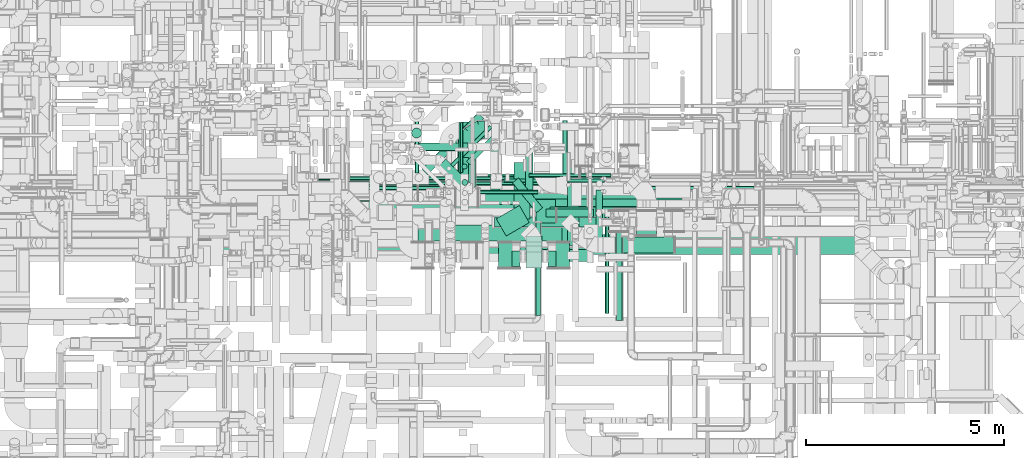
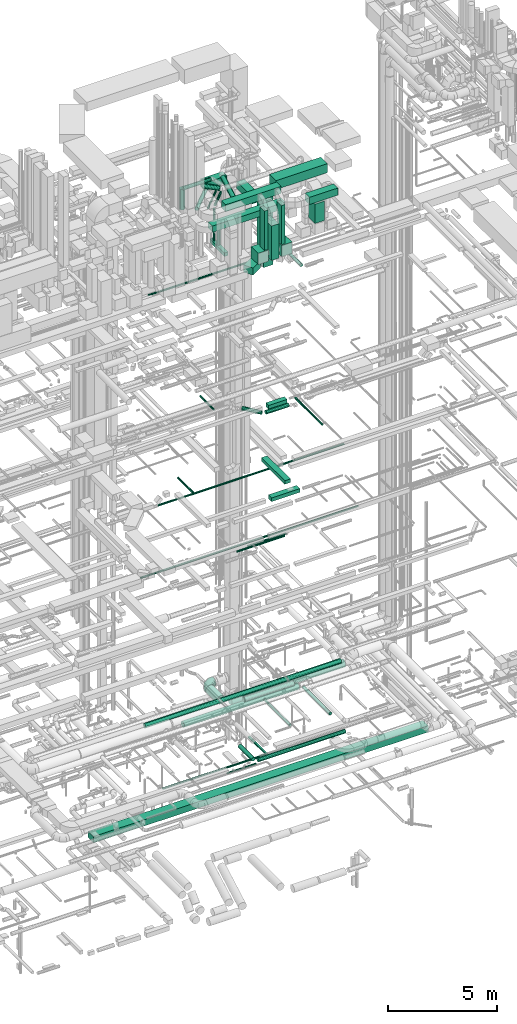
# One storey, part 54 of 337: 51 flow segments, 1 flow fitting.
"""IFC2X3 building model written with IfcOpenShell, lengths in millimetres."""

from ifc_helpers import new_model, entity, si_unit, converted_unit, derived_unit, direction, frame, origin, origin_2d_with_axis, place, context, subcontext, project, spatial, rectangle, circle, extrude, faceted_brep, source, transform, mapped, material, type_object, type_shapes, element, save


model = new_model("IFC2X3")

# Units and contexts
model_context = context("Model", 3, precision=0.01, world=origin(), true_north=direction((6.12303176911189e-17, 1.0)))
body_context = subcontext(model_context, "Body", "Model", "MODEL_VIEW")
ifc_project = project(units=[si_unit("LENGTHUNIT", "METRE", prefix="MILLI"), si_unit("AREAUNIT", "SQUARE_METRE"), si_unit("VOLUMEUNIT", "CUBIC_METRE"), converted_unit("PLANEANGLEUNIT", "DEGREE", entity("IfcRatioMeasure", 0.0174532925199433), si_unit("PLANEANGLEUNIT", "RADIAN"), dimensions=[0, 0, 0, 0, 0, 0, 0]), si_unit("MASSUNIT", "GRAM", prefix="KILO"), derived_unit("MASSDENSITYUNIT", [(si_unit("MASSUNIT", "GRAM", prefix="KILO"), 1), (si_unit("LENGTHUNIT", "METRE"), -3)]), derived_unit("MOMENTOFINERTIAUNIT", [(si_unit("LENGTHUNIT", "METRE"), 4)]), si_unit("TIMEUNIT", "SECOND"), si_unit("FREQUENCYUNIT", "HERTZ"), si_unit("THERMODYNAMICTEMPERATUREUNIT", "DEGREE_CELSIUS"), derived_unit("THERMALTRANSMITTANCEUNIT", [(si_unit("MASSUNIT", "GRAM", prefix="KILO"), 1), (si_unit("THERMODYNAMICTEMPERATUREUNIT", "KELVIN"), -1), (si_unit("TIMEUNIT", "SECOND"), -3)]), derived_unit("VOLUMETRICFLOWRATEUNIT", [(si_unit("LENGTHUNIT", "METRE"), 3), (si_unit("TIMEUNIT", "SECOND"), -1)]), derived_unit("MASSFLOWRATEUNIT", [(si_unit("MASSUNIT", "GRAM", prefix="KILO"), 1), (si_unit("TIMEUNIT", "SECOND"), -1)]), derived_unit("ROTATIONALFREQUENCYUNIT", [(si_unit("TIMEUNIT", "SECOND"), -1)]), si_unit("ELECTRICCURRENTUNIT", "AMPERE"), si_unit("ELECTRICVOLTAGEUNIT", "VOLT"), si_unit("POWERUNIT", "WATT"), si_unit("FORCEUNIT", "NEWTON", prefix="KILO"), si_unit("ILLUMINANCEUNIT", "LUX"), si_unit("LUMINOUSFLUXUNIT", "LUMEN"), si_unit("LUMINOUSINTENSITYUNIT", "CANDELA"), derived_unit("USERDEFINED", [(si_unit("MASSUNIT", "GRAM", prefix="KILO"), -1), (si_unit("LENGTHUNIT", "METRE"), -2), (si_unit("TIMEUNIT", "SECOND"), 3), (si_unit("LUMINOUSFLUXUNIT", "LUMEN"), 1)]), derived_unit("LINEARVELOCITYUNIT", [(si_unit("LENGTHUNIT", "METRE"), 1), (si_unit("TIMEUNIT", "SECOND"), -1)]), si_unit("PRESSUREUNIT", "PASCAL"), derived_unit("USERDEFINED", [(si_unit("LENGTHUNIT", "METRE"), -2), (si_unit("MASSUNIT", "GRAM", prefix="KILO"), 1), (si_unit("TIMEUNIT", "SECOND"), -2)]), derived_unit("LINEARFORCEUNIT", [(si_unit("MASSUNIT", "GRAM", prefix="KILO"), 1), (si_unit("LENGTHUNIT", "METRE"), 1), (si_unit("TIMEUNIT", "SECOND"), -2), (si_unit("LENGTHUNIT", "METRE"), -1)]), derived_unit("PLANARFORCEUNIT", [(si_unit("MASSUNIT", "GRAM", prefix="KILO"), 1), (si_unit("LENGTHUNIT", "METRE"), 1), (si_unit("TIMEUNIT", "SECOND"), -2), (si_unit("LENGTHUNIT", "METRE"), -2)])], contexts=[model_context])

# Site, building, storey
site_placement = place(None, origin())
site = spatial("IfcSite", under=ifc_project, at=site_placement, CompositionType="ELEMENT")
building_placement = place(site_placement, origin())
building = spatial("IfcBuilding", under=site, at=building_placement, CompositionType="ELEMENT")
storey_placement = place(building_placement, origin())
storey = spatial("IfcBuildingStorey", under=building, at=storey_placement, CompositionType="ELEMENT", Elevation=0.0)

# Flow segments
duct_segment_type_1 = type_object("IfcDuctSegmentType", PredefinedType="NOTDEFINED")
flow_segment_1_placement = place(storey_placement, frame((49863.6, 8300.37, -1095.0)))
element("IfcFlowSegment", 1, at=flow_segment_1_placement, inside=storey, type_object=duct_segment_type_1, context=body_context, shape_type="SweptSolid", body=[
    extrude(rectangle(XDim=17725.52076, YDim=500.0, at=origin_2d_with_axis()), frame((8862.76, 250.0, 0.0), z_axis=(0.0, 0.0, 1.0), x_axis=(-1.0, 0.0, 0.0)), (0.0, 0.0, 1.0), 350.0),
])
flow_segment_2_placement = place(storey_placement, frame((59679.84, 9245.12, 19175.0)))
element("IfcFlowSegment", 2, at=flow_segment_2_placement, inside=storey, type_object=duct_segment_type_1, context=body_context, shape_type="SweptSolid", body=[
    extrude(rectangle(XDim=980.000000000003, YDim=249.999999999999, at=origin_2d_with_axis()), frame((490.0, 125.0, 0.0)), (0.0, 0.0, 1.0), 199.999999999998),
])
flow_segment_3_placement = place(storey_placement, frame((60120.56, 8519.63, 15250.0)))
element("IfcFlowSegment", 3, at=flow_segment_3_placement, inside=storey, type_object=duct_segment_type_1, context=body_context, shape_type="SweptSolid", body=[
    extrude(rectangle(XDim=2145.00000000002, YDim=300.000000000001, at=origin_2d_with_axis()), frame((150.0, 1072.5, 0.0), z_axis=(0.0, 0.0, 1.0), x_axis=(0.0, -1.0, 0.0)), (0.0, 0.0, 1.0), 200.000000000002),
])
flow_segment_4_placement = place(storey_placement, frame((59190.56, 8119.63, 14850.0)))
element("IfcFlowSegment", 4, at=flow_segment_4_placement, inside=storey, type_object=duct_segment_type_1, context=body_context, shape_type="SweptSolid", body=[
    extrude(rectangle(XDim=1500.0, YDim=300.0, at=origin_2d_with_axis()), frame((750.0, 150.0, 0.0)), (0.0, 0.0, 1.0), 200.000000000002),
])
flow_segment_5_placement = place(storey_placement, frame((59325.64, 9088.57, 27306.46)))
element("IfcFlowSegment", 5, at=flow_segment_5_placement, inside=storey, type_object=duct_segment_type_1, context=body_context, shape_type="SweptSolid", body=[
    extrude(rectangle(XDim=600.0, YDim=499.999999999999, at=origin_2d_with_axis()), frame((250.0, 300.0, 0.0), z_axis=(0.0, 0.0, 1.0), x_axis=(0.0, -1.0, 0.0)), (0.0, 0.0, 1.0), 3993.54236280399),
])
flow_segment_6_placement = place(storey_placement, frame((61870.03, 8786.6, 29070.0)))
element("IfcFlowSegment", 6, at=flow_segment_6_placement, inside=storey, type_object=duct_segment_type_1, context=body_context, shape_type="SweptSolid", body=[
    extrude(rectangle(XDim=500.000000000008, YDim=600.0, at=origin_2d_with_axis()), frame((250.0, 300.0, 0.0), z_axis=(0.0, 0.0, 1.0), x_axis=(-1.0, 0.0, 0.0)), (0.0, 0.0, 1.0), 1080.00002998999),
])
flow_segment_7_placement = place(storey_placement, frame((61323.5, 8336.6, 30600.0)))
element("IfcFlowSegment", 7, at=flow_segment_7_placement, inside=storey, type_object=duct_segment_type_1, context=body_context, shape_type="SweptSolid", body=[
    extrude(rectangle(XDim=1496.99999999988, YDim=400.0, at=origin_2d_with_axis()), frame((748.5, 200.0, 0.0), z_axis=(0.0, 0.0, 1.0), x_axis=(-1.0, 0.0, 0.0)), (0.0, 0.0, 1.0), 399.999999999996),
])
flow_segment_8_placement = place(storey_placement, frame((56361.0, 8636.6, 30600.0)))
element("IfcFlowSegment", 8, at=flow_segment_8_placement, inside=storey, type_object=duct_segment_type_1, context=body_context, shape_type="SweptSolid", body=[
    extrude(rectangle(XDim=3847.2072124502, YDim=400.0, at=origin_2d_with_axis()), frame((1923.6, 200.0, 0.0), z_axis=(0.0, 0.0, 1.0), x_axis=(-1.0, 0.0, 0.0)), (0.0, 0.0, 1.0), 349.999999999998),
])
flow_segment_9_placement = place(storey_placement, frame((57447.0, 11239.32, 31000.0)))
element("IfcFlowSegment", 9, at=flow_segment_9_placement, inside=storey, type_object=duct_segment_type_1, context=body_context, shape_type="SweptSolid", body=[
    extrude(rectangle(XDim=1182.90417000001, YDim=400.0, at=origin_2d_with_axis()), frame((591.45, 200.0, 0.0), z_axis=(0.0, 0.0, 1.0), x_axis=(-1.0, 0.0, 0.0)), (0.0, 0.0, 1.0), 400.000000000004),
])
for number, where in (
    (10, (58380.38, 7958.29, 28502.0)),
    (11, (59630.38, 7958.29, 28502.0)),
):
    element("IfcFlowSegment", number, at=place(storey_placement, frame(where)), inside=storey, type_object=duct_segment_type_1, context=body_context, shape_type="SweptSolid", body=[
        extrude(rectangle(XDim=630.0, YDim=549.999999999996, at=origin_2d_with_axis()), frame((275.0, 315.0, 0.0), z_axis=(0.0, 0.0, 1.0), x_axis=(0.0, 1.0, 0.0)), (0.0, 0.0, 1.0), 630.000000000004),
    ])
flow_segment_10_placement = place(storey_placement, frame((59630.38, 7988.0, 29152.0)))
element("IfcFlowSegment", 12, at=flow_segment_10_placement, inside=storey, type_object=duct_segment_type_1, context=body_context, shape_type="SweptSolid", body=[
    extrude(rectangle(XDim=200.000000000007, YDim=400.0, at=origin_2d_with_axis()), frame((100.0, 200.0, 0.0)), (0.0, 0.0, 1.0), 2197.99997500005),
])
flow_segment_11_placement = place(storey_placement, frame((57060.5, 8638.29, 31500.0)))
element("IfcFlowSegment", 13, at=flow_segment_11_placement, inside=storey, type_object=duct_segment_type_1, context=body_context, shape_type="SweptSolid", body=[
    extrude(rectangle(XDim=2925.88456999998, YDim=400.0, at=origin_2d_with_axis()), frame((1462.94, 200.0, 0.0)), (0.0, 0.0, 1.0), 399.999999999996),
])
flow_segment_12_placement = place(storey_placement, frame((58730.38, 7988.0, 29152.0)))
element("IfcFlowSegment", 14, at=flow_segment_12_placement, inside=storey, type_object=duct_segment_type_1, context=body_context, shape_type="SweptSolid", body=[
    extrude(rectangle(XDim=200.000000000007, YDim=400.0, at=origin_2d_with_axis()), frame((100.0, 200.0, 0.0)), (0.0, 0.0, 1.0), 2197.99997500005),
])
flow_segment_13_placement = place(storey_placement, frame((58329.55, 8762.06, 27350.0)))
element("IfcFlowSegment", 15, at=flow_segment_13_placement, inside=storey, type_object=duct_segment_type_1, context=body_context, shape_type="SweptSolid", body=[
    extrude(rectangle(XDim=672.825030727756, YDim=499.999999999994, at=origin_2d_with_axis()), frame((416.34, 384.71, 0.0), z_axis=(0.0, 0.0, 1.0), x_axis=(0.86602540378444, 0.499999999999997, 0.0)), (0.0, 0.0, 1.0), 400.000000000004),
])
flow_segment_14_placement = place(storey_placement, frame((58780.38, 9194.29, 31000.0)))
element("IfcFlowSegment", 16, at=flow_segment_14_placement, inside=storey, type_object=duct_segment_type_1, context=body_context, shape_type="SweptSolid", body=[
    extrude(rectangle(XDim=1421.34163000006, YDim=400.000000000004, at=origin_2d_with_axis()), frame((200.0, 710.67, 0.0), z_axis=(0.0, 0.0, 1.0), x_axis=(0.0, 1.0, 0.0)), (0.0, 0.0, 1.0), 400.000000000004),
])
flow_segment_15_placement = place(storey_placement, frame((59080.38, 7960.0, 28475.0)))
element("IfcFlowSegment", 17, at=flow_segment_15_placement, inside=storey, type_object=duct_segment_type_1, context=body_context, shape_type="SweptSolid", body=[
    extrude(rectangle(XDim=800.000000000001, YDim=399.999999999996, at=origin_2d_with_axis()), frame((200.0, 400.0, 0.0), z_axis=(0.0, 0.0, 1.0), x_axis=(0.0, -1.0, 0.0)), (0.0, 0.0, 1.0), 1926.76945188012),
])
flow_segment_16_placement = place(storey_placement, frame((57431.19, 9402.81, 28400.0)))
element("IfcFlowSegment", 18, at=flow_segment_16_placement, inside=storey, type_object=duct_segment_type_1, context=body_context, shape_type="SweptSolid", body=[
    extrude(rectangle(XDim=1340.0, YDim=199.999999999998, at=origin_2d_with_axis()), frame((100.0, 670.0, 0.0), z_axis=(0.0, 0.0, 1.0), x_axis=(0.0, -1.0, 0.0)), (0.0, 0.0, 1.0), 199.999999999998),
])
duct_segment_type_2 = type_object("IfcDuctSegmentType", PredefinedType="NOTDEFINED")
flow_segment_17_placement = place(storey_placement, frame((59998.56, 10005.87, -849.1)))
element("IfcFlowSegment", 19, at=flow_segment_17_placement, inside=storey, type_object=duct_segment_type_2, context=body_context, shape_type="SweptSolid", body=[
    extrude(circle(Radius=62.5, at=origin_2d_with_axis()), frame((64.1, 0.0, 64.1), z_axis=(0.0, 1.0, 0.0), x_axis=(-1.0, 0.0, 0.0)), (0.0, 0.0, 1.0), 1675.0),
])
flow_segment_18_placement = place(storey_placement, frame((54546.9, 10031.99, -836.6)))
element("IfcFlowSegment", 20, at=flow_segment_18_placement, inside=storey, type_object=duct_segment_type_2, context=body_context, shape_type="SweptSolid", body=[
    extrude(circle(Radius=50.0, at=origin_2d_with_axis()), frame((0.0, 51.6, 51.6), z_axis=(1.0, 0.0, 0.0), x_axis=(0.0, -1.0, 0.0)), (0.0, 0.0, 1.0), 5433.24657999997),
])
flow_segment_19_placement = place(storey_placement, frame((59060.41, 9748.98, -651.6)))
element("IfcFlowSegment", 21, at=flow_segment_19_placement, inside=storey, type_object=duct_segment_type_2, context=body_context, shape_type="SweptSolid", body=[
    extrude(circle(Radius=100.0, at=origin_2d_with_axis()), frame((101.6, 0.0, 101.6), z_axis=(0.0, 1.0, 0.0), x_axis=(1.0, 0.0, 0.0)), (0.0, 0.0, 1.0), 1225.42779752531),
])
flow_segment_20_placement = place(storey_placement, frame((57831.35, 9821.97, -1001.6)))
element("IfcFlowSegment", 22, at=flow_segment_20_placement, inside=storey, type_object=duct_segment_type_2, context=body_context, shape_type="SweptSolid", body=[
    extrude(circle(Radius=50.0, at=origin_2d_with_axis()), frame((0.0, 51.6, 51.6), z_axis=(1.0, 0.0, 0.0), x_axis=(0.0, -1.0, 0.0)), (0.0, 0.0, 1.0), 1556.34530999995),
])
flow_segment_21_placement = place(storey_placement, frame((57358.53, 10000.0, 2939.23)))
element("IfcFlowSegment", 23, at=flow_segment_21_placement, inside=storey, type_object=duct_segment_type_2, context=body_context, shape_type="SweptSolid", body=[
    extrude(circle(Radius=225.0, at=origin_2d_with_axis()), frame((226.6, 0.0, 226.6), z_axis=(0.0, 1.0, 0.0), x_axis=(1.0, 0.0, 0.0)), (0.0, 0.0, 1.0), 989.573923827316),
])
flow_segment_22_placement = place(storey_placement, frame((59155.78, 10234.73, 10998.4)))
element("IfcFlowSegment", 24, at=flow_segment_22_placement, inside=storey, type_object=duct_segment_type_2, context=body_context, shape_type="SweptSolid", body=[
    extrude(circle(Radius=50.0, at=origin_2d_with_axis()), frame((0.0, 51.6, 51.6), z_axis=(1.0, 0.0, 0.0), x_axis=(0.0, -1.0, 0.0)), (0.0, 0.0, 1.0), 2061.43743244448),
])
flow_segment_23_placement = place(storey_placement, frame((58527.28, 10104.0, 10998.4)))
element("IfcFlowSegment", 25, at=flow_segment_23_placement, inside=storey, type_object=duct_segment_type_2, context=body_context, shape_type="SweptSolid", body=[
    extrude(circle(Radius=50.0, at=origin_2d_with_axis()), frame((0.0, 51.6, 51.6), z_axis=(1.0, 0.0, 0.0), x_axis=(0.0, -1.0, 0.0)), (0.0, 0.0, 1.0), 2528.57879028175),
])
flow_segment_24_placement = place(storey_placement, frame((57387.84, 10357.4, 19198.4)))
element("IfcFlowSegment", 26, at=flow_segment_24_placement, inside=storey, type_object=duct_segment_type_2, context=body_context, shape_type="SweptSolid", body=[
    extrude(circle(Radius=50.0, at=origin_2d_with_axis()), frame((51.6, 0.0, 51.6), z_axis=(0.0, 1.0, 0.0), x_axis=(1.0, 0.0, 0.0)), (0.0, 0.0, 1.0), 1273.00545368704),
])
flow_segment_25_placement = place(storey_placement, frame((61068.43, 6808.61, 19223.4)))
element("IfcFlowSegment", 27, at=flow_segment_25_placement, inside=storey, type_object=duct_segment_type_2, context=body_context, shape_type="SweptSolid", body=[
    extrude(circle(Radius=50.0, at=origin_2d_with_axis()), frame((51.6, 0.0, 51.6), z_axis=(0.0, 1.0, 0.0), x_axis=(-1.0, 0.0, 0.0)), (0.0, 0.0, 1.0), 2494.01008030507),
])
flow_segment_26_placement = place(storey_placement, frame((54425.03, 10223.45, 14948.4)))
element("IfcFlowSegment", 28, at=flow_segment_26_placement, inside=storey, type_object=duct_segment_type_2, context=body_context, shape_type="SweptSolid", body=[
    extrude(circle(Radius=50.0, at=origin_2d_with_axis()), frame((0.0, 51.6, 51.6), z_axis=(1.0, 0.0, 0.0), x_axis=(0.0, 1.0, 0.0)), (0.0, 0.0, 1.0), 9840.00000000001),
])
flow_segment_27_placement = place(storey_placement, frame((56274.47, 10345.04, 14948.4)))
element("IfcFlowSegment", 29, at=flow_segment_27_placement, inside=storey, type_object=duct_segment_type_2, context=body_context, shape_type="SweptSolid", body=[
    extrude(circle(Radius=50.0, at=origin_2d_with_axis()), frame((51.6, 0.0, 51.6), z_axis=(0.0, 1.0, 0.0), x_axis=(1.0, 0.0, 0.0)), (0.0, 0.0, 1.0), 1395.29999999991),
])
flow_segment_28_placement = place(storey_placement, frame((58735.14, 9348.18, 18873.22)))
element("IfcFlowSegment", 30, at=flow_segment_28_placement, inside=storey, type_object=duct_segment_type_2, context=body_context, shape_type="SweptSolid", body=[
    extrude(circle(Radius=100.0, at=origin_2d_with_axis()), frame((79.31, 815.08, 101.6), z_axis=(0.629320391049814, -0.77714596145699, 0.0), x_axis=(0.77714596145699, 0.629320391049814, 0.0)), (0.0, 0.0, 1.0), 965.778249625125),
])
flow_segment_29_placement = place(storey_placement, frame((59577.67, 9236.98, 18873.22)))
element("IfcFlowSegment", 31, at=flow_segment_29_placement, inside=storey, type_object=duct_segment_type_2, context=body_context, shape_type="SweptSolid", body=[
    extrude(circle(Radius=100.0, at=origin_2d_with_axis()), frame((0.0, 101.6, 101.6), z_axis=(1.0, 0.0, 0.0), x_axis=(0.0, -1.0, 0.0)), (0.0, 0.0, 1.0), 1198.34194170647),
])
flow_segment_30_placement = place(storey_placement, frame((60846.85, 8402.41, 27218.4)))
element("IfcFlowSegment", 32, at=flow_segment_30_placement, inside=storey, type_object=duct_segment_type_2, context=body_context, shape_type="SweptSolid", body=[
    extrude(circle(Radius=80.0, at=origin_2d_with_axis()), frame((81.6, 0.0, 81.6), z_axis=(0.0, 1.0, 0.0), x_axis=(-1.0, 0.0, 0.0)), (0.0, 0.0, 1.0), 1520.0),
])
flow_segment_31_placement = place(storey_placement, frame((53844.42, 10158.38, 26948.4)))
element("IfcFlowSegment", 33, at=flow_segment_31_placement, inside=storey, type_object=duct_segment_type_2, context=body_context, shape_type="SweptSolid", body=[
    extrude(circle(Radius=50.0, at=origin_2d_with_axis()), frame((0.0, 51.6, 51.6), z_axis=(1.0, 0.0, 0.0), x_axis=(0.0, -1.0, 0.0)), (0.0, 0.0, 1.0), 7094.65233084021),
])
flow_segment_32_placement = place(storey_placement, frame((56880.54, 9935.08, 31673.4)))
element("IfcFlowSegment", 34, at=flow_segment_32_placement, inside=storey, type_object=duct_segment_type_2, context=body_context, shape_type="SweptSolid", body=[
    extrude(circle(Radius=125.0, at=origin_2d_with_axis()), frame((88.98, 678.1, 126.6), z_axis=(0.715056088085973, -0.699067086116336, 0.0), x_axis=(-0.699067086116336, -0.715056088085973, 0.0)), (0.0, 0.0, 1.0), 839.864573474785),
])
flow_segment_33_placement = place(storey_placement, frame((57459.9, 10036.46, 28620.0)))
element("IfcFlowSegment", 35, at=flow_segment_33_placement, inside=storey, type_object=duct_segment_type_2, context=body_context, shape_type="SweptSolid", body=[
    extrude(circle(Radius=75.0, at=origin_2d_with_axis()), frame((76.6, 76.6, 0.0), z_axis=(0.0, 0.0, 1.0), x_axis=(-1.0, 0.0, 0.0)), (0.0, 0.0, 1.0), 1059.99999999996),
])
flow_segment_34_placement = place(storey_placement, frame((57170.26, 10496.57, 30448.4)))
element("IfcFlowSegment", 36, at=flow_segment_34_placement, inside=storey, type_object=duct_segment_type_2, context=body_context, shape_type="SweptSolid", body=[
    extrude(circle(Radius=50.0, at=origin_2d_with_axis()), frame((36.95, 36.95, 51.6), z_axis=(0.707106781186554, 0.707106781186541, 0.0), x_axis=(0.707106781186541, -0.707106781186554, 0.0)), (0.0, 0.0, 1.0), 1398.57864376272),
])
flow_segment_35_placement = place(storey_placement, frame((57467.1, 10448.72, 28620.0)))
element("IfcFlowSegment", 37, at=flow_segment_35_placement, inside=storey, type_object=duct_segment_type_2, context=body_context, shape_type="SweptSolid", body=[
    extrude(circle(Radius=62.5, at=origin_2d_with_axis()), frame((64.1, 64.1, 0.0)), (0.0, 0.0, 1.0), 1752.49999999999),
])
flow_segment_36_placement = place(storey_placement, frame((57573.79, 10555.41, 30433.4)))
element("IfcFlowSegment", 38, at=flow_segment_36_placement, inside=storey, type_object=duct_segment_type_2, context=body_context, shape_type="SweptSolid", body=[
    extrude(circle(Radius=62.5, at=origin_2d_with_axis()), frame((45.79, 45.79, 64.1), z_axis=(0.707106781186554, 0.707106781186541, 0.0), x_axis=(-0.707106781186541, 0.707106781186554, 0.0)), (0.0, 0.0, 1.0), 1059.02396590333),
])
flow_segment_37_placement = place(storey_placement, frame((56449.12, 10303.18, 30698.4)))
element("IfcFlowSegment", 39, at=flow_segment_37_placement, inside=storey, type_object=duct_segment_type_2, context=body_context, shape_type="SweptSolid", body=[
    extrude(circle(Radius=100.0, at=origin_2d_with_axis()), frame((72.31, 72.31, 101.6), z_axis=(0.707106781186542, 0.707106781186553, 0.0), x_axis=(0.707106781186553, -0.707106781186542, 0.0)), (0.0, 0.0, 1.0), 2008.42067794927),
])
flow_segment_38_placement = place(storey_placement, frame((56159.0, 10902.63, 31599.45)))
element("IfcFlowSegment", 40, at=flow_segment_38_placement, inside=storey, type_object=duct_segment_type_2, context=body_context, shape_type="SweptSolid", body=[
    extrude(circle(Radius=100.0, at=origin_2d_with_axis()), frame((0.0, 101.6, 101.6), z_axis=(1.0, 0.0, 0.0), x_axis=(0.0, 1.0, 0.0)), (0.0, 0.0, 1.0), 1462.14983405105),
])
flow_segment_39_placement = place(storey_placement, frame((56193.9, 11230.94, 30295.82)))
element("IfcFlowSegment", 41, at=flow_segment_39_placement, inside=storey, type_object=duct_segment_type_2, context=body_context, shape_type="SweptSolid", body=[
    extrude(circle(Radius=125.0, at=origin_2d_with_axis()), frame((126.6, 126.6, 0.0), z_axis=(0.0, 0.0, 1.0), x_axis=(-1.0, 0.0, 0.0)), (0.0, 0.0, 1.0), 1154.17547991571),
])
flow_segment_40_placement = place(storey_placement, frame((58178.44, 9890.53, 30812.35)))
element("IfcFlowSegment", 42, at=flow_segment_40_placement, inside=storey, type_object=duct_segment_type_2, context=body_context, shape_type="SweptSolid", body=[
    extrude(circle(Radius=125.0, at=origin_2d_with_axis()), frame((126.6, 64.1, 109.85), z_axis=(0.0, 0.866025403784435, 0.500000000000006), x_axis=(0.0, 0.500000000000006, -0.866025403784435)), (0.0, 0.0, 1.0), 1307.45626711628),
])
flow_segment_41_placement = place(storey_placement, frame((58286.4, 8982.05, 3373.43)))
element("IfcFlowSegment", 43, at=flow_segment_41_placement, inside=storey, type_object=duct_segment_type_2, context=body_context, shape_type="SweptSolid", body=[
    extrude(circle(Radius=125.0, at=origin_2d_with_axis()), frame((0.0, 126.6, 126.6), z_axis=(1.0, 0.0, -2.03279015452354e-06), x_axis=(0.0, 1.0, 0.0)), (0.0, 0.0, 1.0), 2620.99996522023),
])
flow_segment_42_placement = place(storey_placement, frame((59322.96, 6750.67, 3035.88)))
element("IfcFlowSegment", 44, at=flow_segment_42_placement, inside=storey, type_object=duct_segment_type_2, context=body_context, shape_type="SweptSolid", body=[
    extrude(circle(Radius=62.5, at=origin_2d_with_axis()), frame((64.1, 2347.71, 64.1), z_axis=(0.0, -1.0, 1.21915181881916e-05), x_axis=(1.0, 0.0, 0.0)), (0.0, 0.0, 1.0), 2347.71334194841),
])
flow_segment_43_placement = place(storey_placement, frame((61356.42, 6625.67, 3018.4)))
element("IfcFlowSegment", 45, at=flow_segment_43_placement, inside=storey, type_object=duct_segment_type_2, context=body_context, shape_type="SweptSolid", body=[
    extrude(circle(Radius=80.0, at=origin_2d_with_axis()), frame((81.6, 0.0, 81.6), z_axis=(0.0, 1.0, 0.0), x_axis=(-1.0, 0.0, 0.0)), (0.0, 0.0, 1.0), 2452.71541143044),
])
flow_segment_44_placement = place(storey_placement, frame((55144.83, 9116.79, 2940.9)))
element("IfcFlowSegment", 46, at=flow_segment_44_placement, inside=storey, type_object=duct_segment_type_2, context=body_context, shape_type="SweptSolid", body=[
    extrude(circle(Radius=157.5, at=origin_2d_with_axis()), frame((0.0, 159.1, 159.1), z_axis=(1.0, 0.0, 0.0), x_axis=(0.0, 1.0, 0.0)), (0.0, 0.0, 1.0), 6108.43145732592),
])
flow_segment_45_placement = place(storey_placement, frame((57925.32, 9548.4, 2966.44)))
element("IfcFlowSegment", 47, at=flow_segment_45_placement, inside=storey, type_object=duct_segment_type_2, context=body_context, shape_type="SweptSolid", body=[
    extrude(circle(Radius=200.0, at=origin_2d_with_axis()), frame((0.0, 201.6, 201.6), z_axis=(1.0, 0.0, 0.0), x_axis=(0.0, -1.0, 0.0)), (0.0, 0.0, 1.0), 6016.49865140724),
])
flow_segment_46_placement = place(storey_placement, frame((53269.56, 9405.9, 3393.4)))
element("IfcFlowSegment", 48, at=flow_segment_46_placement, inside=storey, type_object=duct_segment_type_2, context=body_context, shape_type="SweptSolid", body=[
    extrude(circle(Radius=125.0, at=origin_2d_with_axis()), frame((0.0, 126.6, 126.6), z_axis=(1.0, 0.0, 0.0), x_axis=(0.0, 1.0, 0.0)), (0.0, 0.0, 1.0), 10378.4062043357),
])
flow_segment_47_placement = place(storey_placement, frame((53309.89, 9915.2, 11468.4)))
element("IfcFlowSegment", 49, at=flow_segment_47_placement, inside=storey, type_object=duct_segment_type_2, context=body_context, shape_type="SweptSolid", body=[
    extrude(circle(Radius=50.0, at=origin_2d_with_axis()), frame((0.0, 51.6, 51.6), z_axis=(1.0, 0.0, 0.0), x_axis=(0.0, -1.0, 0.0)), (0.0, 0.0, 1.0), 11522.5957397877),
])
flow_segment_48_placement = place(storey_placement, frame((59312.01, 9497.39, -651.6)))
element("IfcFlowSegment", 50, at=flow_segment_48_placement, inside=storey, type_object=duct_segment_type_2, context=body_context, shape_type="SweptSolid", body=[
    extrude(circle(Radius=100.0, at=origin_2d_with_axis()), frame((0.0, 101.6, 101.6), z_axis=(1.0, 0.0, 0.0), x_axis=(0.0, -1.0, 0.0)), (0.0, 0.0, 1.0), 4621.77068899),
])
duct_segment_type_3 = type_object("IfcDuctSegmentType", PredefinedType="NOTDEFINED")
flow_segment_49_placement = place(storey_placement, frame((59975.64, 9088.57, 31450.0)))
element("IfcFlowSegment", 51, at=flow_segment_49_placement, inside=storey, type_object=duct_segment_type_3, context=body_context, shape_type="SweptSolid", body=[
    extrude(rectangle(XDim=2734.46987209406, YDim=600.0, at=origin_2d_with_axis()), frame((1367.23, 300.0, 0.0), z_axis=(0.0, 0.0, 1.0), x_axis=(-1.0, 0.0, 0.0)), (0.0, 0.0, 1.0), 499.999999999999),
])

# Flow fitting
ifc_material = material()
duct_fitting_type = type_object("IfcDuctFittingType", PredefinedType="NOTDEFINED", material=ifc_material)
shared_shape = source(origin(), body_context, "Body", "Brep", [
    faceted_brep([(-450.0, 0.0, -225.0), (-450.0, -50.07, -219.36), (-450.0, -97.62, -202.72), (-450.0, -140.29, -175.91), (-450.0, -175.91, -140.29), (-450.0, -202.72, -97.62), (-450.0, -219.36, -50.07), (-450.0, -225.0, 0.0), (-450.0, -219.36, 50.07), (-450.0, -202.72, 97.62), (-450.0, -175.91, 140.29), (-450.0, -140.29, 175.91), (-450.0, -97.62, 202.72), (-450.0, -50.07, 219.36), (-450.0, 0.0, 225.0), (-450.0, 50.07, 219.36), (-450.0, 97.62, 202.72), (-450.0, 140.29, 175.91), (-450.0, 175.91, 140.29), (-450.0, 202.72, 97.62), (-450.0, 219.36, 50.07), (-450.0, 225.0, 0.0), (-450.0, 219.36, -50.07), (-450.0, 202.72, -97.62), (-450.0, 175.91, -140.29), (-450.0, 140.29, -175.91), (-450.0, 97.62, -202.72), (-450.0, 50.07, -219.36), (-329.42, 0.0, 225.0), (-342.84, 50.07, 219.36), (-355.58, 97.62, 202.72), (-367.01, 140.29, 175.91), (-376.56, 175.91, 140.29), (-383.74, 202.72, 97.62), (-388.2, 219.36, 50.07), (-389.71, 225.0, 0.0), (-388.2, 219.36, -50.07), (-383.74, 202.72, -97.62), (-376.56, 175.91, -140.29), (-367.01, 140.29, -175.91), (-355.58, 97.62, -202.72), (-342.84, 50.07, -219.36), (-329.42, 0.0, -225.0), (-316.01, -50.07, -219.36), (-303.26, -97.62, -202.72), (-291.83, -140.29, -175.91), (-282.29, -175.91, -140.29), (-275.1, -202.72, -97.62), (-270.65, -219.36, -50.07), (-269.13, -225.0, 0.0), (-270.65, -219.36, 50.07), (-275.1, -202.72, 97.62), (-282.29, -175.91, 140.29), (-291.83, -140.29, 175.91), (-303.26, -97.62, 202.72), (-316.01, -50.07, 219.36), (-120.58, 120.58, 225.0), (-157.23, 157.23, 219.36), (-192.04, 192.04, 202.72), (-223.27, 223.27, 175.91), (-249.35, 249.35, 140.29), (-268.98, 268.98, 97.62), (-281.16, 281.16, 50.07), (-285.29, 285.29, 0.0), (-281.16, 281.16, -50.07), (-268.98, 268.98, -97.62), (-249.35, 249.35, -140.29), (-223.27, 223.27, -175.91), (-192.04, 192.04, -202.72), (-157.23, 157.23, -219.36), (-120.58, 120.58, -225.0), (-83.93, 83.93, -219.36), (-49.11, 49.11, -202.72), (-17.88, 17.88, -175.91), (8.2, -8.2, -140.29), (27.82, -27.82, -97.62), (40.0, -40.0, -50.07), (44.13, -44.13, 0.0), (40.0, -40.0, 50.07), (27.82, -27.82, 97.62), (8.2, -8.2, 140.29), (-17.88, 17.88, 175.91), (-49.11, 49.11, 202.72), (-83.93, 83.93, 219.36), (0.0, 329.42, 225.0), (-50.07, 342.84, 219.36), (-97.62, 355.58, 202.72), (-140.29, 367.01, 175.91), (-175.91, 376.56, 140.29), (-202.72, 383.74, 97.62), (-219.36, 388.2, 50.07), (-225.0, 389.71, 0.0), (-219.36, 388.2, -50.07), (-202.72, 383.74, -97.62), (-175.91, 376.56, -140.29), (-140.29, 367.01, -175.91), (-97.62, 355.58, -202.72), (-50.07, 342.84, -219.36), (0.0, 329.42, -225.0), (50.07, 316.01, -219.36), (97.62, 303.26, -202.72), (140.29, 291.83, -175.91), (175.91, 282.29, -140.29), (202.72, 275.1, -97.62), (219.36, 270.65, -50.07), (225.0, 269.13, 0.0), (219.36, 270.65, 50.07), (202.72, 275.1, 97.62), (175.91, 282.29, 140.29), (140.29, 291.83, 175.91), (97.62, 303.26, 202.72), (50.07, 316.01, 219.36), (-50.07, 450.0, -219.36), (-97.62, 450.0, -202.72), (-140.29, 450.0, -175.91), (-175.91, 450.0, -140.29), (-202.72, 450.0, -97.62), (-219.36, 450.0, -50.07), (-225.0, 450.0, 0.0), (-219.36, 450.0, 50.07), (-202.72, 450.0, 97.62), (-175.91, 450.0, 140.29), (-140.29, 450.0, 175.91), (-97.62, 450.0, 202.72), (-50.07, 450.0, 219.36), (0.0, 450.0, 225.0), (50.07, 450.0, 219.36), (97.62, 450.0, 202.72), (140.29, 450.0, 175.91), (175.91, 450.0, 140.29), (202.72, 450.0, 97.62), (219.36, 450.0, 50.07), (225.0, 450.0, 0.0), (219.36, 450.0, -50.07), (202.72, 450.0, -97.62), (175.91, 450.0, -140.29), (140.29, 450.0, -175.91), (97.62, 450.0, -202.72), (50.07, 450.0, -219.36), (0.0, 450.0, -225.0)], [[[0, 1, 2, 3, 4, 5, 6, 7, 8, 9, 10, 11, 12, 13, 14, 15, 16, 17, 18, 19, 20, 21, 22, 23, 24, 25, 26, 27]], [[28, 29, 15, 14]], [[30, 31, 17, 16]], [[29, 30, 16, 15]], [[31, 32, 18, 17]], [[32, 33, 19, 18]], [[34, 35, 21, 20]], [[33, 34, 20, 19]], [[35, 36, 22, 21]], [[37, 38, 24, 23]], [[36, 37, 23, 22]], [[38, 39, 25, 24]], [[39, 40, 26, 25]], [[41, 42, 0, 27]], [[40, 41, 27, 26]], [[1, 0, 42, 43]], [[43, 44, 2, 1]], [[45, 3, 2, 44]], [[45, 46, 4, 3]], [[5, 4, 46, 47]], [[47, 48, 6, 5]], [[49, 7, 6, 48]], [[7, 49, 50, 8]], [[8, 50, 51, 9]], [[9, 51, 52, 10]], [[52, 53, 11, 10]], [[11, 53, 54, 12]], [[12, 54, 55, 13]], [[13, 55, 28, 14]], [[56, 57, 29, 28]], [[58, 59, 31, 30]], [[57, 58, 30, 29]], [[59, 60, 32, 31]], [[60, 61, 33, 32]], [[62, 63, 35, 34]], [[61, 62, 34, 33]], [[63, 64, 36, 35]], [[65, 66, 38, 37]], [[64, 65, 37, 36]], [[66, 67, 39, 38]], [[67, 68, 40, 39]], [[69, 70, 42, 41]], [[68, 69, 41, 40]], [[43, 42, 70, 71]], [[71, 72, 44, 43]], [[73, 45, 44, 72]], [[73, 74, 46, 45]], [[47, 46, 74, 75]], [[75, 76, 48, 47]], [[77, 49, 48, 76]], [[50, 49, 77, 78]], [[51, 50, 78, 79]], [[52, 51, 79, 80]], [[80, 81, 53, 52]], [[54, 53, 81, 82]], [[55, 54, 82, 83]], [[28, 55, 83, 56]], [[84, 85, 57, 56]], [[86, 87, 59, 58]], [[85, 86, 58, 57]], [[87, 88, 60, 59]], [[88, 89, 61, 60]], [[90, 91, 63, 62]], [[89, 90, 62, 61]], [[91, 92, 64, 63]], [[93, 94, 66, 65]], [[92, 93, 65, 64]], [[94, 95, 67, 66]], [[95, 96, 68, 67]], [[97, 98, 70, 69]], [[96, 97, 69, 68]], [[71, 70, 98, 99]], [[99, 100, 72, 71]], [[101, 73, 72, 100]], [[101, 102, 74, 73]], [[75, 74, 102, 103]], [[103, 104, 76, 75]], [[105, 77, 76, 104]], [[78, 77, 105, 106]], [[79, 78, 106, 107]], [[80, 79, 107, 108]], [[108, 109, 81, 80]], [[82, 81, 109, 110]], [[83, 82, 110, 111]], [[56, 83, 111, 84]], [[112, 113, 114, 115, 116, 117, 118, 119, 120, 121, 122, 123, 124, 125, 126, 127, 128, 129, 130, 131, 132, 133, 134, 135, 136, 137, 138, 139]], [[85, 84, 125, 124]], [[86, 85, 124, 123]], [[87, 86, 123, 122]], [[122, 121, 88, 87]], [[89, 88, 121, 120]], [[90, 89, 120, 119]], [[91, 90, 119, 118]], [[91, 118, 117, 92]], [[116, 115, 94, 93]], [[92, 117, 116, 93]], [[115, 114, 95, 94]], [[95, 114, 113, 96]], [[96, 113, 112, 97]], [[97, 112, 139, 98]], [[98, 139, 138, 99]], [[99, 138, 137, 100]], [[100, 137, 136, 101]], [[136, 135, 102, 101]], [[102, 135, 134, 103]], [[103, 134, 133, 104]], [[104, 133, 132, 105]], [[106, 105, 132, 131]], [[107, 106, 131, 130]], [[108, 107, 130, 129]], [[129, 128, 109, 108]], [[110, 109, 128, 127]], [[111, 110, 127, 126]], [[84, 111, 126, 125]]]),
])
type_shapes(duct_fitting_type, [shared_shape])
flow_fitting_placement = place(storey_placement, frame((57585.12, 11439.57, 3165.82), z_axis=(0.0, 0.0, 1.0), x_axis=(-1.0, 0.0, 0.0)))
element("IfcFlowFitting", 52, at=flow_fitting_placement, inside=storey, type_object=duct_fitting_type, material=ifc_material, context=body_context, shape_type="MappedRepresentation", body=[
    mapped(shared_shape, transform((0.0, 0.0, 0.0), scale=1.0)),
])

save(model, "model.ifc")
